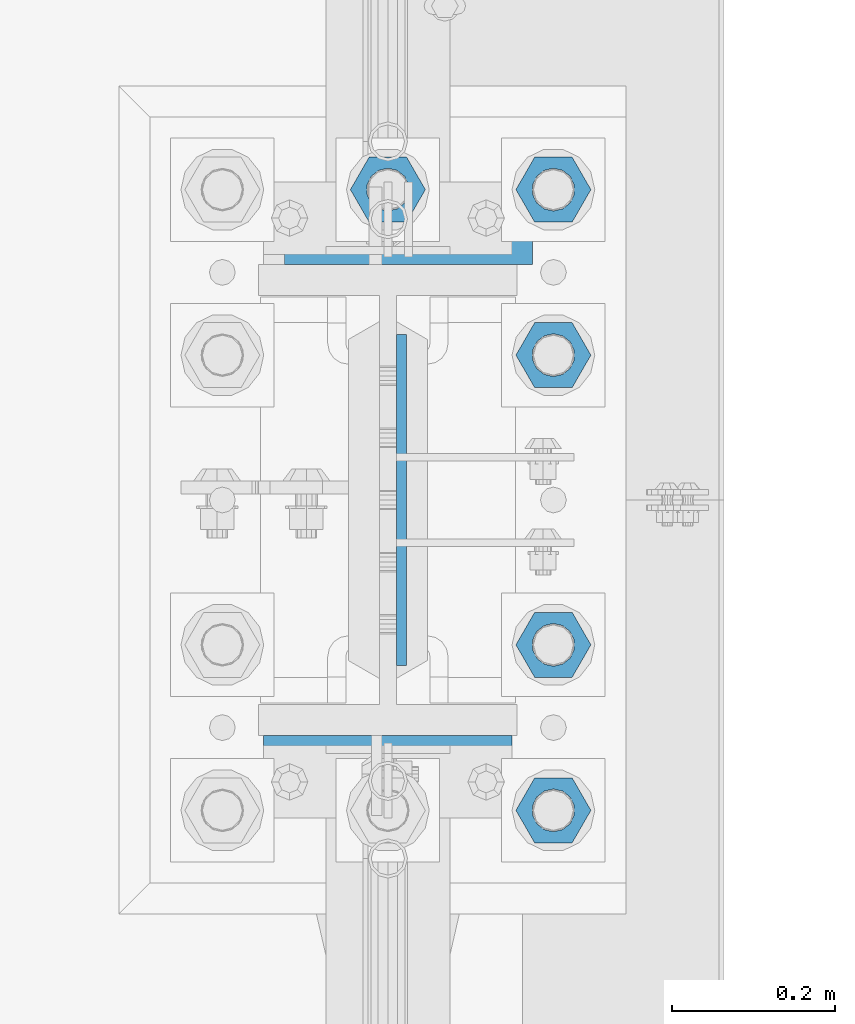
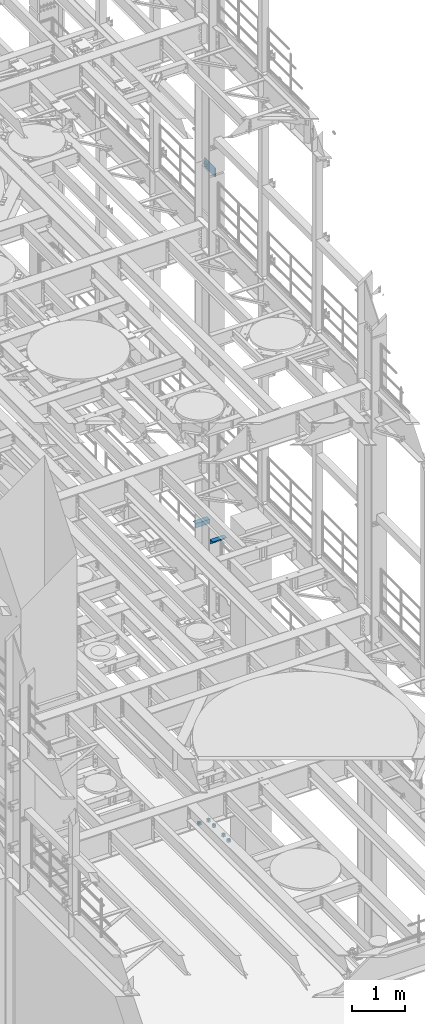
# One storey, part 1339 of 1876: 8 beams, 2 elements without a shape of their own.
"""IFC2X3 building model written with IfcOpenShell, lengths in millimetres."""

from ifc_helpers import new_model, si_unit, frame, origin_with_axes, place, context, subcontext, project, spatial, faceted_brep, material, type_object, element, aggregate, save


model = new_model("IFC2X3")

# Units and contexts
model_context = context("Model", 3, precision=1e-05, world=origin_with_axes())
body_context = subcontext(model_context, "Body", "Model", "MODEL_VIEW")
ifc_project = project(units=[si_unit("LENGTHUNIT", "METRE", prefix="MILLI"), si_unit("AREAUNIT", "SQUARE_METRE"), si_unit("VOLUMEUNIT", "CUBIC_METRE"), si_unit("MASSUNIT", "GRAM", prefix="KILO"), si_unit("TIMEUNIT", "SECOND"), si_unit("PLANEANGLEUNIT", "RADIAN"), si_unit("SOLIDANGLEUNIT", "STERADIAN"), si_unit("THERMODYNAMICTEMPERATUREUNIT", "DEGREE_CELSIUS"), si_unit("LUMINOUSINTENSITYUNIT", "LUMEN")], contexts=[model_context])

# Site, building, storey
site_placement = place(None, origin_with_axes())
site = spatial("IfcSite", under=ifc_project, at=site_placement, CompositionType="ELEMENT")
building_placement = place(site_placement, origin_with_axes())
building = spatial("IfcBuilding", under=site, at=building_placement, Name="Undefined", CompositionType="ELEMENT")
storey_placement = place(building_placement, origin_with_axes())
storey = spatial("IfcBuildingStorey", under=building, at=storey_placement, Name="Undefined", CompositionType="ELEMENT", Elevation=0.0)

# Assembly, beams
assembly_1_placement = place(storey_placement, origin_with_axes())
assembly_1 = element("IfcElementAssembly", 1, at=assembly_1_placement, inside=storey, Name="COLUMN", AssemblyPlace="NOTDEFINED", PredefinedType="RIGID_FRAME")
ifc_material_1 = material(Name="STEEL/A36")
beam_type_1 = type_object("IfcBeamType", Name="L4X4X3/8", PredefinedType="NOTDEFINED")
beam_1_placement = place(assembly_1_placement, frame((7797.8, 7959.725, 6194.425), z_axis=(0.0, 1.0, 0.0), x_axis=(-1.0, 0.0, 0.0)))
beam_1 = element("IfcBeam", 2, at=beam_1_placement, type_object=beam_type_1, material=ifc_material_1, Name="ANGLE", ObjectType="L4X4X3/8", context=body_context, shape_type="Brep", body=[
    faceted_brep([(0.0, 50.7999999999993, -50.8000000000002), (0.0, 50.7999999999993, 50.8000000000002), (304.799999999999, 50.7999999999993, 50.8000000000002), (304.799999999999, 50.7999999999993, -50.8000000000002), (0.0, 41.2750000000015, 50.8000000000002), (304.799999999999, 41.2750000000015, 50.8000000000002), (0.0, 41.2750000000015, -41.2749999999996), (304.799999999999, 41.2750000000015, -41.2749999999996), (0.0, -50.7999999999993, -41.2749999999996), (304.799999999999, -50.7999999999993, -41.2749999999996), (0.0, -50.7999999999993, -50.8000000000002), (304.799999999999, -50.7999999999993, -50.8000000000002)], [[[0, 1, 2, 3]], [[1, 4, 5, 2]], [[4, 6, 7, 5]], [[6, 8, 9, 7]], [[8, 10, 11, 9]], [[10, 0, 3, 11]], [[5, 7, 9, 11, 3, 2]], [[10, 8, 6, 4, 1, 0]]]),
])
beam_2_placement = place(assembly_1_placement, frame((7467.6, 7280.275, 6194.425), z_axis=(0.0, -1.0, 0.0), x_axis=(1.0, 0.0, 0.0)))
beam_2 = element("IfcBeam", 3, at=beam_2_placement, type_object=beam_type_1, material=ifc_material_1, Name="ANGLE", ObjectType="L4X4X3/8", context=body_context, shape_type="Brep", body=[
    faceted_brep([(0.0, 50.7999999999993, -50.8000000000002), (0.0, 50.7999999999993, 50.8000000000002), (304.799999999999, 50.7999999999993, 50.8000000000002), (304.799999999999, 50.7999999999993, -50.8000000000002), (0.0, 41.2750000000015, 50.8000000000002), (304.799999999999, 41.2750000000015, 50.8000000000002), (0.0, 41.2750000000015, -41.2749999999996), (304.799999999999, 41.2750000000015, -41.2749999999996), (0.0, -50.7999999999993, -41.2749999999996), (304.799999999999, -50.7999999999993, -41.2749999999996), (0.0, -50.7999999999993, -50.8000000000002), (304.799999999999, -50.7999999999993, -50.8000000000002)], [[[0, 1, 2, 3]], [[1, 4, 5, 2]], [[4, 6, 7, 5]], [[6, 8, 9, 7]], [[8, 10, 11, 9]], [[10, 0, 3, 11]], [[5, 7, 9, 11, 3, 2]], [[10, 8, 6, 4, 1, 0]]]),
])
ifc_material_2 = material(Name="STEEL/A572-50")
beam_type_2 = type_object("IfcBeamType", PredefinedType="NOTDEFINED")
beam_3_placement = place(assembly_1_placement, frame((7636.66875, 7620.0, 14636.75), z_axis=(0.0, 1.0, 0.0), x_axis=(0.0, 0.0, -1.0)))
beam_3 = element("IfcBeam", 4, at=beam_3_placement, type_object=beam_type_2, material=ifc_material_2, Name="PLATE", context=body_context, shape_type="Brep", body=[
    faceted_brep([(0.0, 6.35000000000036, -203.2), (0.0, 6.35000000000036, 203.2), (209.550000000001, 6.35000000000036, 203.2), (209.550000000001, 6.35000000000036, -203.2), (0.0, -6.35000000000036, 203.2), (209.550000000001, -6.35000000000036, 203.2), (0.0, -6.35000000000036, -203.2), (209.550000000001, -6.35000000000036, -203.2)], [[[0, 1, 2, 3]], [[1, 4, 5, 2]], [[4, 6, 7, 5]], [[6, 0, 3, 7]], [[5, 7, 3, 2]], [[6, 4, 1, 0]]]),
])
aggregate(assembly_1, [beam_1, beam_2, beam_3])

assembly_2_placement = place(storey_placement, origin_with_axes())
assembly_2 = element("IfcElementAssembly", 5, at=assembly_2_placement, inside=storey, Name="TEMPLATE", AssemblyPlace="NOTDEFINED", PredefinedType="RIGID_FRAME")
ifc_material_3 = material(Name="STEEL/A563")
beam_type_3 = type_object("IfcBeamType", Name="2_HEAVY_HEX_NUT", PredefinedType="NOTDEFINED")
beam_4_placement = place(assembly_2_placement, frame((7823.2, 7238.99999847412, -685.799998474121), z_axis=(0.0, 1.0, 0.0), x_axis=(0.0, 0.0, -1.0)))
beam_4 = element("IfcBeam", 6, at=beam_4_placement, type_object=beam_type_3, material=ifc_material_3, Name="NUT", ObjectType="2_HEAVY_HEX_NUT", context=body_context, shape_type="Brep", body=[
    faceted_brep([(0.0, -46.0369987487793, 9.09494701772928e-13), (0.0, -23.0184993743896, -39.869213104248), (50.8, -23.0184993743896, -39.869213104248), (50.8, -46.0369987487793, 9.09494701772928e-13), (0.0, 23.0184993743896, -39.869213104248), (50.8, 23.0184993743896, -39.869213104248), (0.0, 46.0369987487793, -9.09494701772928e-13), (50.8, 46.0369987487793, -9.09494701772928e-13), (0.0, 23.0184993743896, 39.869213104248), (50.8, 23.0184993743896, 39.869213104248), (0.0, -23.0184993743896, 39.869213104248), (50.8, -23.0184993743896, 39.869213104248), (0.0, 0.0, 26.1940002441406), (0.0, 11.3650617044514, 23.5999013092769), (50.8, 11.3650617044513, 23.5999013092771), (50.8, 0.0, 26.1940002441406), (0.0, 20.4791109456437, 16.3316083006703), (50.8, 20.4791109456439, 16.3316083006703), (0.0, 25.5370200498346, 5.82867859874477), (50.8, 25.5370200498343, 5.82867859874455), (0.0, 25.5370200498346, -5.82867859874477), (50.8, 25.5370200498343, -5.82867859874455), (0.0, 20.4791109456437, -16.3316083006703), (50.8, 20.4791109456439, -16.3316083006703), (0.0, 11.3650617044514, -23.5999013092769), (50.8, 11.3650617044514, -23.5999013092771), (0.0, 0.0, -26.1940002441406), (50.8, 0.0, -26.1940002441406), (0.0, -11.3650617044514, -23.5999013092769), (50.8, -11.3650617044513, -23.5999013092771), (0.0, -20.4791109456437, -16.3316083006703), (50.8, -20.4791109456439, -16.3316083006703), (0.0, -25.5370200498346, -5.82867859874477), (50.8, -25.5370200498343, -5.82867859874455), (0.0, -25.5370200498346, 5.82867859874477), (50.8, -25.5370200498343, 5.82867859874455), (0.0, -20.4791109456437, 16.3316083006703), (50.8, -20.4791109456439, 16.3316083006703), (0.0, -11.3650617044514, 23.5999013092769), (50.8, -11.3650617044514, 23.5999013092771)], [[[0, 1, 2, 3]], [[1, 4, 5, 2]], [[4, 6, 7, 5]], [[6, 8, 9, 7]], [[8, 10, 11, 9]], [[10, 0, 3, 11]], [[12, 13, 14, 15]], [[13, 16, 17, 14]], [[16, 18, 19, 17]], [[18, 20, 21, 19]], [[20, 22, 23, 21]], [[22, 24, 25, 23]], [[24, 26, 27, 25]], [[26, 28, 29, 27]], [[28, 30, 31, 29]], [[30, 32, 33, 31]], [[32, 34, 35, 33]], [[34, 36, 37, 35]], [[36, 38, 39, 37]], [[38, 12, 15, 39]], [[5, 7, 9, 11, 3, 2], [17, 19, 21, 23, 25, 27, 29, 31, 33, 35, 37, 39, 15, 14]], [[10, 8, 6, 4, 1, 0], [38, 36, 34, 32, 30, 28, 26, 24, 22, 20, 18, 16, 13, 12]]]),
])
beam_5_placement = place(assembly_2_placement, frame((7823.2, 7442.19999847412, -685.799998474121), z_axis=(0.0, 1.0, 0.0), x_axis=(0.0, 0.0, -1.0)))
beam_5 = element("IfcBeam", 7, at=beam_5_placement, type_object=beam_type_3, material=ifc_material_3, Name="NUT", ObjectType="2_HEAVY_HEX_NUT", context=body_context, shape_type="Brep", body=[
    faceted_brep([(0.0, -46.0369987487793, 9.09494701772928e-13), (0.0, -23.0184993743896, -39.869213104248), (50.8, -23.0184993743896, -39.869213104248), (50.8, -46.0369987487793, 9.09494701772928e-13), (0.0, 23.0184993743896, -39.869213104248), (50.8, 23.0184993743896, -39.869213104248), (0.0, 46.0369987487793, -9.09494701772928e-13), (50.8, 46.0369987487793, -9.09494701772928e-13), (0.0, 23.0184993743896, 39.869213104248), (50.8, 23.0184993743896, 39.869213104248), (0.0, -23.0184993743896, 39.869213104248), (50.8, -23.0184993743896, 39.869213104248), (0.0, 0.0, 26.1940002441406), (0.0, 11.3650617044514, 23.5999013092769), (50.8, 11.3650617044513, 23.5999013092771), (50.8, 0.0, 26.1940002441406), (0.0, 20.4791109456437, 16.3316083006703), (50.8, 20.4791109456439, 16.3316083006703), (0.0, 25.5370200498346, 5.82867859874477), (50.8, 25.5370200498343, 5.82867859874455), (0.0, 25.5370200498346, -5.82867859874477), (50.8, 25.5370200498343, -5.82867859874455), (0.0, 20.4791109456437, -16.3316083006703), (50.8, 20.4791109456439, -16.3316083006703), (0.0, 11.3650617044514, -23.5999013092769), (50.8, 11.3650617044514, -23.5999013092771), (0.0, 0.0, -26.1940002441406), (50.8, 0.0, -26.1940002441406), (0.0, -11.3650617044514, -23.5999013092769), (50.8, -11.3650617044513, -23.5999013092771), (0.0, -20.4791109456437, -16.3316083006703), (50.8, -20.4791109456439, -16.3316083006703), (0.0, -25.5370200498346, -5.82867859874477), (50.8, -25.5370200498343, -5.82867859874455), (0.0, -25.5370200498346, 5.82867859874477), (50.8, -25.5370200498343, 5.82867859874455), (0.0, -20.4791109456437, 16.3316083006703), (50.8, -20.4791109456439, 16.3316083006703), (0.0, -11.3650617044514, 23.5999013092769), (50.8, -11.3650617044514, 23.5999013092771)], [[[0, 1, 2, 3]], [[1, 4, 5, 2]], [[4, 6, 7, 5]], [[6, 8, 9, 7]], [[8, 10, 11, 9]], [[10, 0, 3, 11]], [[12, 13, 14, 15]], [[13, 16, 17, 14]], [[16, 18, 19, 17]], [[18, 20, 21, 19]], [[20, 22, 23, 21]], [[22, 24, 25, 23]], [[24, 26, 27, 25]], [[26, 28, 29, 27]], [[28, 30, 31, 29]], [[30, 32, 33, 31]], [[32, 34, 35, 33]], [[34, 36, 37, 35]], [[36, 38, 39, 37]], [[38, 12, 15, 39]], [[5, 7, 9, 11, 3, 2], [17, 19, 21, 23, 25, 27, 29, 31, 33, 35, 37, 39, 15, 14]], [[10, 8, 6, 4, 1, 0], [38, 36, 34, 32, 30, 28, 26, 24, 22, 20, 18, 16, 13, 12]]]),
])
beam_6_placement = place(assembly_2_placement, frame((7823.2, 7797.79999847412, -685.799998474121), z_axis=(0.0, 1.0, 0.0), x_axis=(0.0, 0.0, -1.0)))
beam_6 = element("IfcBeam", 8, at=beam_6_placement, type_object=beam_type_3, material=ifc_material_3, Name="NUT", ObjectType="2_HEAVY_HEX_NUT", context=body_context, shape_type="Brep", body=[
    faceted_brep([(0.0, -46.0369987487793, 9.09494701772928e-13), (0.0, -23.0184993743896, -39.869213104248), (50.8, -23.0184993743896, -39.869213104248), (50.8, -46.0369987487793, 9.09494701772928e-13), (0.0, 23.0184993743896, -39.869213104248), (50.8, 23.0184993743896, -39.869213104248), (0.0, 46.0369987487793, -9.09494701772928e-13), (50.8, 46.0369987487793, -9.09494701772928e-13), (0.0, 23.0184993743896, 39.869213104248), (50.8, 23.0184993743896, 39.869213104248), (0.0, -23.0184993743896, 39.869213104248), (50.8, -23.0184993743896, 39.869213104248), (0.0, 0.0, 26.1940002441406), (0.0, 11.3650617044514, 23.5999013092769), (50.8, 11.3650617044513, 23.5999013092771), (50.8, 0.0, 26.1940002441406), (0.0, 20.4791109456437, 16.3316083006703), (50.8, 20.4791109456439, 16.3316083006703), (0.0, 25.5370200498346, 5.82867859874477), (50.8, 25.5370200498343, 5.82867859874455), (0.0, 25.5370200498346, -5.82867859874477), (50.8, 25.5370200498343, -5.82867859874455), (0.0, 20.4791109456437, -16.3316083006703), (50.8, 20.4791109456439, -16.3316083006703), (0.0, 11.3650617044514, -23.5999013092769), (50.8, 11.3650617044514, -23.5999013092771), (0.0, 0.0, -26.1940002441406), (50.8, 0.0, -26.1940002441406), (0.0, -11.3650617044514, -23.5999013092769), (50.8, -11.3650617044513, -23.5999013092771), (0.0, -20.4791109456437, -16.3316083006703), (50.8, -20.4791109456439, -16.3316083006703), (0.0, -25.5370200498346, -5.82867859874477), (50.8, -25.5370200498343, -5.82867859874455), (0.0, -25.5370200498346, 5.82867859874477), (50.8, -25.5370200498343, 5.82867859874455), (0.0, -20.4791109456437, 16.3316083006703), (50.8, -20.4791109456439, 16.3316083006703), (0.0, -11.3650617044514, 23.5999013092769), (50.8, -11.3650617044514, 23.5999013092771)], [[[0, 1, 2, 3]], [[1, 4, 5, 2]], [[4, 6, 7, 5]], [[6, 8, 9, 7]], [[8, 10, 11, 9]], [[10, 0, 3, 11]], [[12, 13, 14, 15]], [[13, 16, 17, 14]], [[16, 18, 19, 17]], [[18, 20, 21, 19]], [[20, 22, 23, 21]], [[22, 24, 25, 23]], [[24, 26, 27, 25]], [[26, 28, 29, 27]], [[28, 30, 31, 29]], [[30, 32, 33, 31]], [[32, 34, 35, 33]], [[34, 36, 37, 35]], [[36, 38, 39, 37]], [[38, 12, 15, 39]], [[5, 7, 9, 11, 3, 2], [17, 19, 21, 23, 25, 27, 29, 31, 33, 35, 37, 39, 15, 14]], [[10, 8, 6, 4, 1, 0], [38, 36, 34, 32, 30, 28, 26, 24, 22, 20, 18, 16, 13, 12]]]),
])
beam_7_placement = place(assembly_2_placement, frame((7620.0, 8000.99999847412, -685.799998474121), z_axis=(0.0, -1.0, 0.0), x_axis=(0.0, 0.0, -1.0)))
beam_7 = element("IfcBeam", 9, at=beam_7_placement, type_object=beam_type_3, material=ifc_material_3, Name="NUT", ObjectType="2_HEAVY_HEX_NUT", context=body_context, shape_type="Brep", body=[
    faceted_brep([(0.0, -46.0369987487793, 9.09494701772928e-13), (0.0, -23.0184993743896, -39.869213104248), (50.8, -23.0184993743896, -39.869213104248), (50.8, -46.0369987487793, 9.09494701772928e-13), (0.0, 23.0184993743896, -39.869213104248), (50.8, 23.0184993743896, -39.869213104248), (0.0, 46.0369987487793, -9.09494701772928e-13), (50.8, 46.0369987487793, -9.09494701772928e-13), (0.0, 23.0184993743896, 39.869213104248), (50.8, 23.0184993743896, 39.869213104248), (0.0, -23.0184993743896, 39.869213104248), (50.8, -23.0184993743896, 39.869213104248), (0.0, 0.0, 26.1940002441406), (0.0, 11.3650617044514, 23.5999013092769), (50.8, 11.3650617044513, 23.5999013092771), (50.8, 0.0, 26.1940002441406), (0.0, 20.4791109456437, 16.3316083006703), (50.8, 20.4791109456439, 16.3316083006703), (0.0, 25.5370200498346, 5.82867859874477), (50.8, 25.5370200498343, 5.82867859874455), (0.0, 25.5370200498346, -5.82867859874477), (50.8, 25.5370200498343, -5.82867859874455), (0.0, 20.4791109456437, -16.3316083006703), (50.8, 20.4791109456439, -16.3316083006703), (0.0, 11.3650617044514, -23.5999013092769), (50.8, 11.3650617044514, -23.5999013092771), (0.0, 0.0, -26.1940002441406), (50.8, 0.0, -26.1940002441406), (0.0, -11.3650617044514, -23.5999013092769), (50.8, -11.3650617044513, -23.5999013092771), (0.0, -20.4791109456437, -16.3316083006703), (50.8, -20.4791109456439, -16.3316083006703), (0.0, -25.5370200498346, -5.82867859874477), (50.8, -25.5370200498343, -5.82867859874455), (0.0, -25.5370200498346, 5.82867859874477), (50.8, -25.5370200498343, 5.82867859874455), (0.0, -20.4791109456437, 16.3316083006703), (50.8, -20.4791109456439, 16.3316083006703), (0.0, -11.3650617044514, 23.5999013092769), (50.8, -11.3650617044514, 23.5999013092771)], [[[0, 1, 2, 3]], [[1, 4, 5, 2]], [[4, 6, 7, 5]], [[6, 8, 9, 7]], [[8, 10, 11, 9]], [[10, 0, 3, 11]], [[12, 13, 14, 15]], [[13, 16, 17, 14]], [[16, 18, 19, 17]], [[18, 20, 21, 19]], [[20, 22, 23, 21]], [[22, 24, 25, 23]], [[24, 26, 27, 25]], [[26, 28, 29, 27]], [[28, 30, 31, 29]], [[30, 32, 33, 31]], [[32, 34, 35, 33]], [[34, 36, 37, 35]], [[36, 38, 39, 37]], [[38, 12, 15, 39]], [[5, 7, 9, 11, 3, 2], [17, 19, 21, 23, 25, 27, 29, 31, 33, 35, 37, 39, 15, 14]], [[10, 8, 6, 4, 1, 0], [38, 36, 34, 32, 30, 28, 26, 24, 22, 20, 18, 16, 13, 12]]]),
])
beam_8_placement = place(assembly_2_placement, frame((7823.2, 8000.99999847412, -685.799998474121), z_axis=(0.0, 1.0, 0.0), x_axis=(0.0, 0.0, -1.0)))
beam_8 = element("IfcBeam", 10, at=beam_8_placement, type_object=beam_type_3, material=ifc_material_3, Name="NUT", ObjectType="2_HEAVY_HEX_NUT", context=body_context, shape_type="Brep", body=[
    faceted_brep([(0.0, -46.0369987487793, 9.09494701772928e-13), (0.0, -23.0184993743896, -39.869213104248), (50.8, -23.0184993743896, -39.869213104248), (50.8, -46.0369987487793, 9.09494701772928e-13), (0.0, 23.0184993743896, -39.869213104248), (50.8, 23.0184993743896, -39.869213104248), (0.0, 46.0369987487793, -9.09494701772928e-13), (50.8, 46.0369987487793, -9.09494701772928e-13), (0.0, 23.0184993743896, 39.869213104248), (50.8, 23.0184993743896, 39.869213104248), (0.0, -23.0184993743896, 39.869213104248), (50.8, -23.0184993743896, 39.869213104248), (0.0, 0.0, 26.1940002441406), (0.0, 11.3650617044514, 23.5999013092769), (50.8, 11.3650617044513, 23.5999013092771), (50.8, 0.0, 26.1940002441406), (0.0, 20.4791109456437, 16.3316083006703), (50.8, 20.4791109456439, 16.3316083006703), (0.0, 25.5370200498346, 5.82867859874477), (50.8, 25.5370200498343, 5.82867859874455), (0.0, 25.5370200498346, -5.82867859874477), (50.8, 25.5370200498343, -5.82867859874455), (0.0, 20.4791109456437, -16.3316083006703), (50.8, 20.4791109456439, -16.3316083006703), (0.0, 11.3650617044514, -23.5999013092769), (50.8, 11.3650617044514, -23.5999013092771), (0.0, 0.0, -26.1940002441406), (50.8, 0.0, -26.1940002441406), (0.0, -11.3650617044514, -23.5999013092769), (50.8, -11.3650617044513, -23.5999013092771), (0.0, -20.4791109456437, -16.3316083006703), (50.8, -20.4791109456439, -16.3316083006703), (0.0, -25.5370200498346, -5.82867859874477), (50.8, -25.5370200498343, -5.82867859874455), (0.0, -25.5370200498346, 5.82867859874477), (50.8, -25.5370200498343, 5.82867859874455), (0.0, -20.4791109456437, 16.3316083006703), (50.8, -20.4791109456439, 16.3316083006703), (0.0, -11.3650617044514, 23.5999013092769), (50.8, -11.3650617044514, 23.5999013092771)], [[[0, 1, 2, 3]], [[1, 4, 5, 2]], [[4, 6, 7, 5]], [[6, 8, 9, 7]], [[8, 10, 11, 9]], [[10, 0, 3, 11]], [[12, 13, 14, 15]], [[13, 16, 17, 14]], [[16, 18, 19, 17]], [[18, 20, 21, 19]], [[20, 22, 23, 21]], [[22, 24, 25, 23]], [[24, 26, 27, 25]], [[26, 28, 29, 27]], [[28, 30, 31, 29]], [[30, 32, 33, 31]], [[32, 34, 35, 33]], [[34, 36, 37, 35]], [[36, 38, 39, 37]], [[38, 12, 15, 39]], [[5, 7, 9, 11, 3, 2], [17, 19, 21, 23, 25, 27, 29, 31, 33, 35, 37, 39, 15, 14]], [[10, 8, 6, 4, 1, 0], [38, 36, 34, 32, 30, 28, 26, 24, 22, 20, 18, 16, 13, 12]]]),
])
aggregate(assembly_2, [beam_4, beam_5, beam_6, beam_7, beam_8])

save(model, "model.ifc")
